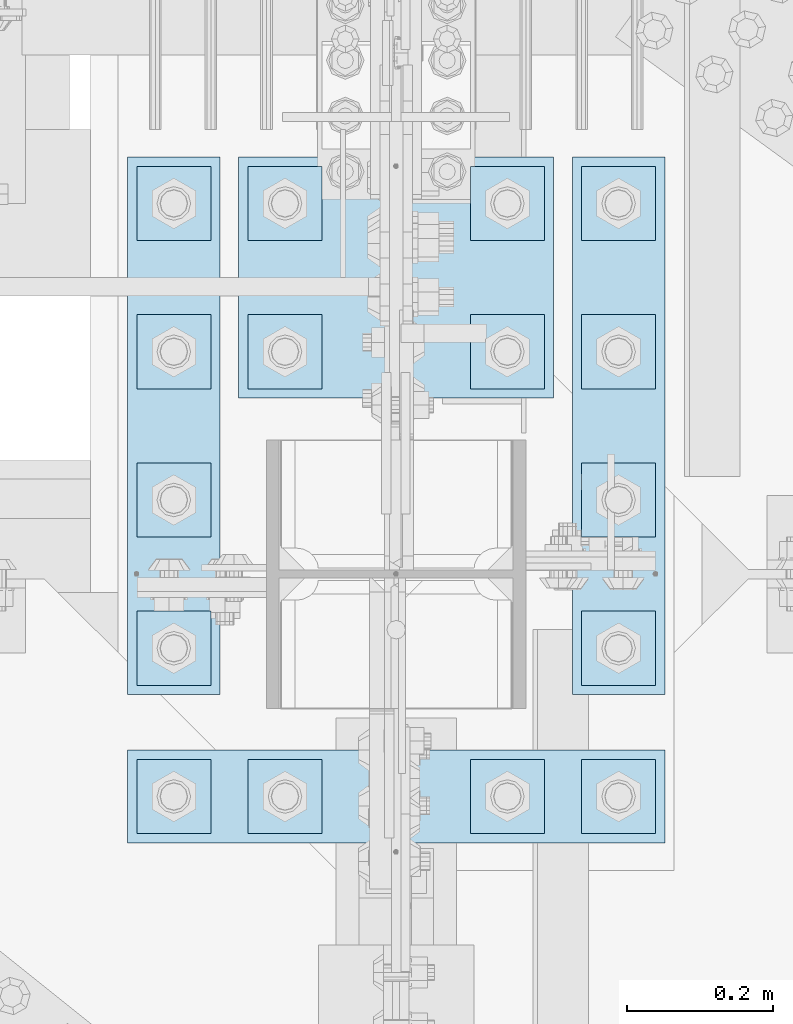
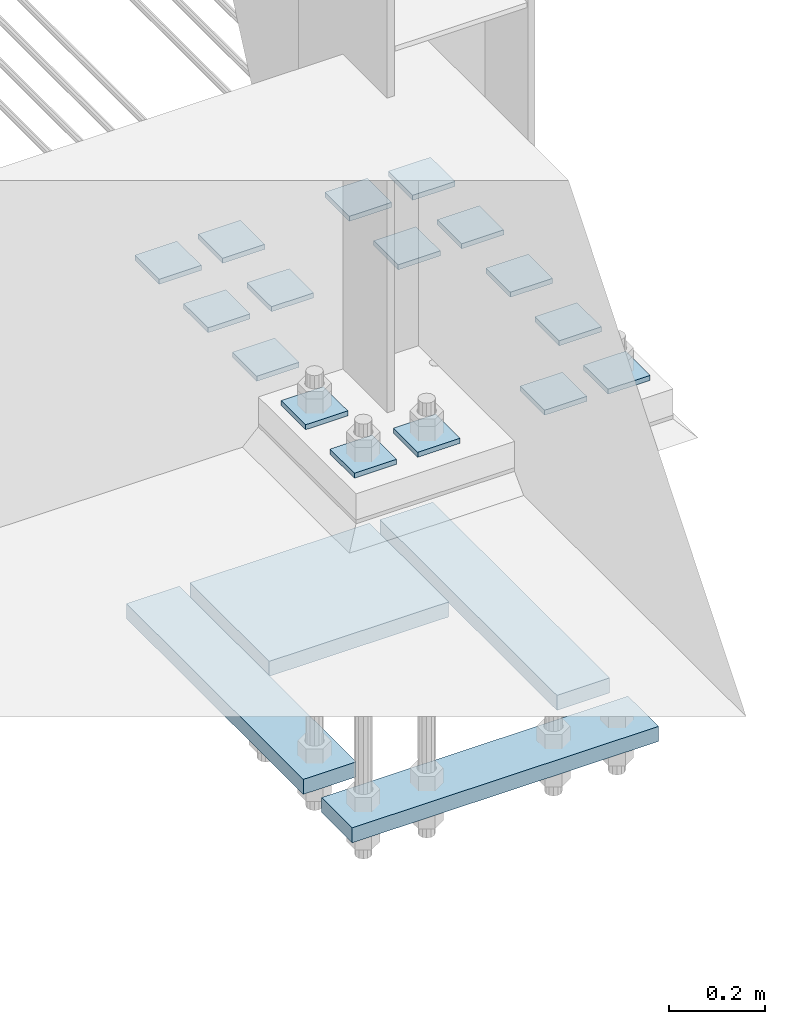
# One storey, part 3515 of 3843: 20 plates, 1 element without a shape of its own.
"""IFC2X3 building model written with IfcOpenShell, lengths in millimetres."""

from ifc_helpers import new_model, si_unit, frame, origin_with_axes, place, context, subcontext, project, spatial, faceted_brep, material, type_object, element, aggregate, save


model = new_model("IFC2X3")

# Units and contexts
model_context = context("Model", 3, precision=1e-05, world=origin_with_axes())
body_context = subcontext(model_context, "Body", "Model", "MODEL_VIEW")
ifc_project = project(units=[si_unit("LENGTHUNIT", "METRE", prefix="MILLI"), si_unit("AREAUNIT", "SQUARE_METRE"), si_unit("VOLUMEUNIT", "CUBIC_METRE"), si_unit("MASSUNIT", "GRAM", prefix="KILO"), si_unit("TIMEUNIT", "SECOND"), si_unit("PLANEANGLEUNIT", "RADIAN"), si_unit("SOLIDANGLEUNIT", "STERADIAN"), si_unit("THERMODYNAMICTEMPERATUREUNIT", "DEGREE_CELSIUS"), si_unit("LUMINOUSINTENSITYUNIT", "LUMEN")], contexts=[model_context])

# Site, building, storey
site_placement = place(None, origin_with_axes())
site = spatial("IfcSite", under=ifc_project, at=site_placement, CompositionType="ELEMENT")
building_placement = place(site_placement, origin_with_axes())
building = spatial("IfcBuilding", under=site, at=building_placement, Name="Undefined", CompositionType="ELEMENT")
storey_placement = place(building_placement, origin_with_axes())
storey = spatial("IfcBuildingStorey", under=building, at=storey_placement, Name="Undefined", CompositionType="ELEMENT", Elevation=0.0)

# Assembly, plates
assembly_placement = place(storey_placement, origin_with_axes())
assembly = element("IfcElementAssembly", 1, at=assembly_placement, inside=storey, Name="TEMPLATE", AssemblyPlace="NOTDEFINED", PredefinedType="RIGID_FRAME")
ifc_material = material(Name="STEEL/A572-50")
plate_type_1 = type_object("IfcPlateType", PredefinedType="NOTDEFINED")
plate_1_placement = place(assembly_placement, frame((77266.8, 91960.7, 29686.25), z_axis=(0.0, -1.0, 0.0), x_axis=(1.0, 0.0, 0.0)))
plate_1 = element("IfcPlate", 2, at=plate_1_placement, type_object=plate_type_1, material=ifc_material, Name="Washer Plate", context=body_context, shape_type="Brep", body=[
    faceted_brep([(0.0, -6.3499999046162, 0.0), (-1.67347025126219e-10, -6.35000000000582, 101.600000000151), (-1.67347025126219e-10, 6.35000000000582, 101.600000000151), (7.27595761418343e-12, 6.3499999046162, 0.0), (101.599998474121, -6.34999999999854, 101.599998474121), (101.599998474121, 6.34999999999854, 101.599998474121), (101.6, -6.34999999999854, 0.0), (101.6, 6.34999999999854, 0.0)], [[[0, 1, 2, 3]], [[1, 4, 5, 2]], [[4, 6, 7, 5]], [[6, 0, 3, 7]], [[5, 7, 3, 2]], [[6, 4, 1, 0]]]),
])
plate_2_placement = place(assembly_placement, frame((77266.8, 92163.9, 29686.25), z_axis=(0.0, -1.0, 0.0), x_axis=(1.0, 0.0, 0.0)))
plate_2 = element("IfcPlate", 3, at=plate_2_placement, type_object=plate_type_1, material=ifc_material, Name="Washer Plate", context=body_context, shape_type="Brep", body=[
    faceted_brep([(0.0, -6.3499999046162, 0.0), (-1.67347025126219e-10, -6.35000000000582, 101.600000000151), (-1.67347025126219e-10, 6.35000000000582, 101.600000000151), (7.27595761418343e-12, 6.3499999046162, 0.0), (101.599998474121, -6.34999999999854, 101.599998474121), (101.599998474121, 6.34999999999854, 101.599998474121), (101.6, -6.34999999999854, 0.0), (101.6, 6.34999999999854, 0.0)], [[[0, 1, 2, 3]], [[1, 4, 5, 2]], [[4, 6, 7, 5]], [[6, 0, 3, 7]], [[5, 7, 3, 2]], [[6, 4, 1, 0]]]),
])
plate_3_placement = place(assembly_placement, frame((77266.8, 92367.1, 29686.25), z_axis=(0.0, -1.0, 0.0), x_axis=(1.0, 0.0, 0.0)))
plate_3 = element("IfcPlate", 4, at=plate_3_placement, type_object=plate_type_1, material=ifc_material, Name="Washer Plate", context=body_context, shape_type="Brep", body=[
    faceted_brep([(0.0, -6.3499999046162, 0.0), (-1.67347025126219e-10, -6.35000000000582, 101.600000000151), (-1.67347025126219e-10, 6.35000000000582, 101.600000000151), (7.27595761418343e-12, 6.3499999046162, 0.0), (101.599998474121, -6.34999999999854, 101.599998474121), (101.599998474121, 6.34999999999854, 101.599998474121), (101.6, -6.34999999999854, 0.0), (101.6, 6.34999999999854, 0.0)], [[[0, 1, 2, 3]], [[1, 4, 5, 2]], [[4, 6, 7, 5]], [[6, 0, 3, 7]], [[5, 7, 3, 2]], [[6, 4, 1, 0]]]),
])
plate_4_placement = place(assembly_placement, frame((77266.8, 92570.3, 29686.25), z_axis=(0.0, -1.0, 0.0), x_axis=(1.0, 0.0, 0.0)))
plate_4 = element("IfcPlate", 5, at=plate_4_placement, type_object=plate_type_1, material=ifc_material, Name="Washer Plate", context=body_context, shape_type="Brep", body=[
    faceted_brep([(0.0, -6.3499999046162, 0.0), (-1.67347025126219e-10, -6.35000000000582, 101.600000000151), (-1.67347025126219e-10, 6.35000000000582, 101.600000000151), (7.27595761418343e-12, 6.3499999046162, 0.0), (101.599998474121, -6.34999999999854, 101.599998474121), (101.599998474121, 6.34999999999854, 101.599998474121), (101.6, -6.34999999999854, 0.0), (101.6, 6.34999999999854, 0.0)], [[[0, 1, 2, 3]], [[1, 4, 5, 2]], [[4, 6, 7, 5]], [[6, 0, 3, 7]], [[5, 7, 3, 2]], [[6, 4, 1, 0]]]),
])
plate_5_placement = place(assembly_placement, frame((77266.8, 92773.5, 29686.25), z_axis=(0.0, -1.0, 0.0), x_axis=(1.0, 0.0, 0.0)))
plate_5 = element("IfcPlate", 6, at=plate_5_placement, type_object=plate_type_1, material=ifc_material, Name="Washer Plate", context=body_context, shape_type="Brep", body=[
    faceted_brep([(0.0, -6.3499999046162, 0.0), (-1.67347025126219e-10, -6.35000000000582, 101.600000000151), (-1.67347025126219e-10, 6.35000000000582, 101.600000000151), (7.27595761418343e-12, 6.3499999046162, 0.0), (101.599998474121, -6.34999999999854, 101.599998474121), (101.599998474121, 6.34999999999854, 101.599998474121), (101.6, -6.34999999999854, 0.0), (101.6, 6.34999999999854, 0.0)], [[[0, 1, 2, 3]], [[1, 4, 5, 2]], [[4, 6, 7, 5]], [[6, 0, 3, 7]], [[5, 7, 3, 2]], [[6, 4, 1, 0]]]),
])
plate_6_placement = place(assembly_placement, frame((77114.4, 91960.7, 29686.25), z_axis=(0.0, -1.0, 0.0), x_axis=(1.0, 0.0, 0.0)))
plate_6 = element("IfcPlate", 7, at=plate_6_placement, type_object=plate_type_1, material=ifc_material, Name="Washer Plate", context=body_context, shape_type="Brep", body=[
    faceted_brep([(0.0, -6.3499999046162, 0.0), (-1.67347025126219e-10, -6.35000000000582, 101.600000000151), (-1.67347025126219e-10, 6.35000000000582, 101.600000000151), (7.27595761418343e-12, 6.3499999046162, 0.0), (101.599998474121, -6.34999999999854, 101.599998474121), (101.599998474121, 6.34999999999854, 101.599998474121), (101.6, -6.34999999999854, 0.0), (101.6, 6.34999999999854, 0.0)], [[[0, 1, 2, 3]], [[1, 4, 5, 2]], [[4, 6, 7, 5]], [[6, 0, 3, 7]], [[5, 7, 3, 2]], [[6, 4, 1, 0]]]),
])
plate_7_placement = place(assembly_placement, frame((77114.4, 92570.3, 29686.25), z_axis=(0.0, -1.0, 0.0), x_axis=(1.0, 0.0, 0.0)))
plate_7 = element("IfcPlate", 8, at=plate_7_placement, type_object=plate_type_1, material=ifc_material, Name="Washer Plate", context=body_context, shape_type="Brep", body=[
    faceted_brep([(0.0, -6.3499999046162, 0.0), (-1.67347025126219e-10, -6.35000000000582, 101.600000000151), (-1.67347025126219e-10, 6.35000000000582, 101.600000000151), (7.27595761418343e-12, 6.3499999046162, 0.0), (101.599998474121, -6.34999999999854, 101.599998474121), (101.599998474121, 6.34999999999854, 101.599998474121), (101.6, -6.34999999999854, 0.0), (101.6, 6.34999999999854, 0.0)], [[[0, 1, 2, 3]], [[1, 4, 5, 2]], [[4, 6, 7, 5]], [[6, 0, 3, 7]], [[5, 7, 3, 2]], [[6, 4, 1, 0]]]),
])
plate_8_placement = place(assembly_placement, frame((77114.4, 92773.5, 29686.25), z_axis=(0.0, -1.0, 0.0), x_axis=(1.0, 0.0, 0.0)))
plate_8 = element("IfcPlate", 9, at=plate_8_placement, type_object=plate_type_1, material=ifc_material, Name="Washer Plate", context=body_context, shape_type="Brep", body=[
    faceted_brep([(0.0, -6.3499999046162, 0.0), (-1.67347025126219e-10, -6.35000000000582, 101.600000000151), (-1.67347025126219e-10, 6.35000000000582, 101.600000000151), (7.27595761418343e-12, 6.3499999046162, 0.0), (101.599998474121, -6.34999999999854, 101.599998474121), (101.599998474121, 6.34999999999854, 101.599998474121), (101.6, -6.34999999999854, 0.0), (101.6, 6.34999999999854, 0.0)], [[[0, 1, 2, 3]], [[1, 4, 5, 2]], [[4, 6, 7, 5]], [[6, 0, 3, 7]], [[5, 7, 3, 2]], [[6, 4, 1, 0]]]),
])
plate_9_placement = place(assembly_placement, frame((76809.6, 91960.7, 29686.25), z_axis=(0.0, -1.0, 0.0), x_axis=(1.0, 0.0, 0.0)))
plate_9 = element("IfcPlate", 10, at=plate_9_placement, type_object=plate_type_1, material=ifc_material, Name="Washer Plate", context=body_context, shape_type="Brep", body=[
    faceted_brep([(0.0, -6.3499999046162, 0.0), (-1.67347025126219e-10, -6.35000000000582, 101.600000000151), (-1.67347025126219e-10, 6.35000000000582, 101.600000000151), (7.27595761418343e-12, 6.3499999046162, 0.0), (101.599998474121, -6.34999999999854, 101.599998474121), (101.599998474121, 6.34999999999854, 101.599998474121), (101.6, -6.34999999999854, 0.0), (101.6, 6.34999999999854, 0.0)], [[[0, 1, 2, 3]], [[1, 4, 5, 2]], [[4, 6, 7, 5]], [[6, 0, 3, 7]], [[5, 7, 3, 2]], [[6, 4, 1, 0]]]),
])
plate_10_placement = place(assembly_placement, frame((76809.6, 92570.3, 29686.25), z_axis=(0.0, -1.0, 0.0), x_axis=(1.0, 0.0, 0.0)))
plate_10 = element("IfcPlate", 11, at=plate_10_placement, type_object=plate_type_1, material=ifc_material, Name="Washer Plate", context=body_context, shape_type="Brep", body=[
    faceted_brep([(0.0, -6.3499999046162, 0.0), (-1.67347025126219e-10, -6.35000000000582, 101.600000000151), (-1.67347025126219e-10, 6.35000000000582, 101.600000000151), (7.27595761418343e-12, 6.3499999046162, 0.0), (101.599998474121, -6.34999999999854, 101.599998474121), (101.599998474121, 6.34999999999854, 101.599998474121), (101.6, -6.34999999999854, 0.0), (101.6, 6.34999999999854, 0.0)], [[[0, 1, 2, 3]], [[1, 4, 5, 2]], [[4, 6, 7, 5]], [[6, 0, 3, 7]], [[5, 7, 3, 2]], [[6, 4, 1, 0]]]),
])
plate_11_placement = place(assembly_placement, frame((76809.6, 92773.5, 29686.25), z_axis=(0.0, -1.0, 0.0), x_axis=(1.0, 0.0, 0.0)))
plate_11 = element("IfcPlate", 12, at=plate_11_placement, type_object=plate_type_1, material=ifc_material, Name="Washer Plate", context=body_context, shape_type="Brep", body=[
    faceted_brep([(0.0, -6.3499999046162, 0.0), (-1.67347025126219e-10, -6.35000000000582, 101.600000000151), (-1.67347025126219e-10, 6.35000000000582, 101.600000000151), (7.27595761418343e-12, 6.3499999046162, 0.0), (101.599998474121, -6.34999999999854, 101.599998474121), (101.599998474121, 6.34999999999854, 101.599998474121), (101.6, -6.34999999999854, 0.0), (101.6, 6.34999999999854, 0.0)], [[[0, 1, 2, 3]], [[1, 4, 5, 2]], [[4, 6, 7, 5]], [[6, 0, 3, 7]], [[5, 7, 3, 2]], [[6, 4, 1, 0]]]),
])
plate_12_placement = place(assembly_placement, frame((76657.2, 91960.7, 29686.25), z_axis=(0.0, -1.0, 0.0), x_axis=(1.0, 0.0, 0.0)))
plate_12 = element("IfcPlate", 13, at=plate_12_placement, type_object=plate_type_1, material=ifc_material, Name="Washer Plate", context=body_context, shape_type="Brep", body=[
    faceted_brep([(0.0, -6.3499999046162, 0.0), (-1.67347025126219e-10, -6.35000000000582, 101.600000000151), (-1.67347025126219e-10, 6.35000000000582, 101.600000000151), (7.27595761418343e-12, 6.3499999046162, 0.0), (101.599998474121, -6.34999999999854, 101.599998474121), (101.599998474121, 6.34999999999854, 101.599998474121), (101.6, -6.34999999999854, 0.0), (101.6, 6.34999999999854, 0.0)], [[[0, 1, 2, 3]], [[1, 4, 5, 2]], [[4, 6, 7, 5]], [[6, 0, 3, 7]], [[5, 7, 3, 2]], [[6, 4, 1, 0]]]),
])
plate_13_placement = place(assembly_placement, frame((76657.2, 92163.9, 29686.25), z_axis=(0.0, -1.0, 0.0), x_axis=(1.0, 0.0, 0.0)))
plate_13 = element("IfcPlate", 14, at=plate_13_placement, type_object=plate_type_1, material=ifc_material, Name="Washer Plate", context=body_context, shape_type="Brep", body=[
    faceted_brep([(0.0, -6.3499999046162, 0.0), (-1.67347025126219e-10, -6.35000000000582, 101.600000000151), (-1.67347025126219e-10, 6.35000000000582, 101.600000000151), (7.27595761418343e-12, 6.3499999046162, 0.0), (101.599998474121, -6.34999999999854, 101.599998474121), (101.599998474121, 6.34999999999854, 101.599998474121), (101.6, -6.34999999999854, 0.0), (101.6, 6.34999999999854, 0.0)], [[[0, 1, 2, 3]], [[1, 4, 5, 2]], [[4, 6, 7, 5]], [[6, 0, 3, 7]], [[5, 7, 3, 2]], [[6, 4, 1, 0]]]),
])
plate_14_placement = place(assembly_placement, frame((76657.2, 92367.1, 29686.25), z_axis=(0.0, -1.0, 0.0), x_axis=(1.0, 0.0, 0.0)))
plate_14 = element("IfcPlate", 15, at=plate_14_placement, type_object=plate_type_1, material=ifc_material, Name="Washer Plate", context=body_context, shape_type="Brep", body=[
    faceted_brep([(0.0, -6.3499999046162, 0.0), (-1.67347025126219e-10, -6.35000000000582, 101.600000000151), (-1.67347025126219e-10, 6.35000000000582, 101.600000000151), (7.27595761418343e-12, 6.3499999046162, 0.0), (101.599998474121, -6.34999999999854, 101.599998474121), (101.599998474121, 6.34999999999854, 101.599998474121), (101.6, -6.34999999999854, 0.0), (101.6, 6.34999999999854, 0.0)], [[[0, 1, 2, 3]], [[1, 4, 5, 2]], [[4, 6, 7, 5]], [[6, 0, 3, 7]], [[5, 7, 3, 2]], [[6, 4, 1, 0]]]),
])
plate_15_placement = place(assembly_placement, frame((76657.2, 92570.3, 29686.25), z_axis=(0.0, -1.0, 0.0), x_axis=(1.0, 0.0, 0.0)))
plate_15 = element("IfcPlate", 16, at=plate_15_placement, type_object=plate_type_1, material=ifc_material, Name="Washer Plate", context=body_context, shape_type="Brep", body=[
    faceted_brep([(0.0, -6.3499999046162, 0.0), (-1.67347025126219e-10, -6.35000000000582, 101.600000000151), (-1.67347025126219e-10, 6.35000000000582, 101.600000000151), (7.27595761418343e-12, 6.3499999046162, 0.0), (101.599998474121, -6.34999999999854, 101.599998474121), (101.599998474121, 6.34999999999854, 101.599998474121), (101.6, -6.34999999999854, 0.0), (101.6, 6.34999999999854, 0.0)], [[[0, 1, 2, 3]], [[1, 4, 5, 2]], [[4, 6, 7, 5]], [[6, 0, 3, 7]], [[5, 7, 3, 2]], [[6, 4, 1, 0]]]),
])
plate_16_placement = place(assembly_placement, frame((76657.2, 92773.5, 29686.25), z_axis=(0.0, -1.0, 0.0), x_axis=(1.0, 0.0, 0.0)))
plate_16 = element("IfcPlate", 17, at=plate_16_placement, type_object=plate_type_1, material=ifc_material, Name="Washer Plate", context=body_context, shape_type="Brep", body=[
    faceted_brep([(0.0, -6.3499999046162, 0.0), (-1.67347025126219e-10, -6.35000000000582, 101.600000000151), (-1.67347025126219e-10, 6.35000000000582, 101.600000000151), (7.27595761418343e-12, 6.3499999046162, 0.0), (101.599998474121, -6.34999999999854, 101.599998474121), (101.599998474121, 6.34999999999854, 101.599998474121), (101.6, -6.34999999999854, 0.0), (101.6, 6.34999999999854, 0.0)], [[[0, 1, 2, 3]], [[1, 4, 5, 2]], [[4, 6, 7, 5]], [[6, 0, 3, 7]], [[5, 7, 3, 2]], [[6, 4, 1, 0]]]),
])
plate_type_2 = type_object("IfcPlateType", PredefinedType="NOTDEFINED")
plate_17_placement = place(assembly_placement, frame((76644.5, 91973.4, 28784.55), z_axis=(0.0, -1.0, 0.0), x_axis=(1.0, 0.0, 0.0)))
plate_17 = element("IfcPlate", 18, at=plate_17_placement, type_object=plate_type_2, material=ifc_material, Name="PLATE", context=body_context, shape_type="Brep", body=[
    faceted_brep([(0.0, -19.0500000000029, 0.0), (0.0, -19.0499999999993, 127.0), (0.0, 19.0499999999993, 127.0), (0.0, 19.0500000000029, 0.0), (736.599975585938, -19.0499999999993, 127.0), (736.599975585938, 19.0499999999993, 127.0), (736.599975585938, -19.0499999999993, 0.0), (736.599975585938, 19.0499999999993, 0.0)], [[[0, 1, 2, 3]], [[1, 4, 5, 2]], [[4, 6, 7, 5]], [[6, 0, 3, 7]], [[5, 7, 3, 2]], [[6, 4, 1, 0]]]),
])
plate_18_placement = place(assembly_placement, frame((76644.5, 92786.2, 28784.55), z_axis=(0.0, -1.0, 0.0), x_axis=(1.0, 0.0, 0.0)))
plate_18 = element("IfcPlate", 19, at=plate_18_placement, type_object=plate_type_2, material=ifc_material, Name="PLATE", context=body_context, shape_type="Brep", body=[
    faceted_brep([(0.0, -19.0500000000029, 0.0), (0.0, -19.0499999999993, 736.600036621094), (0.0, 19.0499999999993, 736.600036621094), (0.0, 19.0500000000029, 0.0), (127.0, -19.0499999999993, 736.600036621094), (127.0, 19.0499999999993, 736.600036621094), (127.0, -19.0499999999993, 0.0), (127.0, 19.0499999999993, 0.0)], [[[0, 1, 2, 3]], [[1, 4, 5, 2]], [[4, 6, 7, 5]], [[6, 0, 3, 7]], [[5, 7, 3, 2]], [[6, 4, 1, 0]]]),
])
plate_19_placement = place(assembly_placement, frame((77254.1, 92786.2, 28784.55), z_axis=(0.0, -1.0, 0.0), x_axis=(1.0, 0.0, 0.0)))
plate_19 = element("IfcPlate", 20, at=plate_19_placement, type_object=plate_type_2, material=ifc_material, Name="PLATE", context=body_context, shape_type="Brep", body=[
    faceted_brep([(0.0, -19.0500000000029, 0.0), (0.0, -19.0499999999993, 736.600036621094), (0.0, 19.0499999999993, 736.600036621094), (0.0, 19.0500000000029, 0.0), (127.0, -19.0499999999993, 736.600036621094), (127.0, 19.0499999999993, 736.600036621094), (127.0, -19.0499999999993, 0.0), (127.0, 19.0499999999993, 0.0)], [[[0, 1, 2, 3]], [[1, 4, 5, 2]], [[4, 6, 7, 5]], [[6, 0, 3, 7]], [[5, 7, 3, 2]], [[6, 4, 1, 0]]]),
])
plate_type_3 = type_object("IfcPlateType", PredefinedType="NOTDEFINED")
plate_20_placement = place(assembly_placement, frame((76796.9, 92786.2, 28784.55), z_axis=(0.0, -1.0, 0.0), x_axis=(1.0, 0.0, 0.0)))
plate_20 = element("IfcPlate", 21, at=plate_20_placement, type_object=plate_type_3, material=ifc_material, Name="PLATE", context=body_context, shape_type="Brep", body=[
    faceted_brep([(0.0, -19.0500000000029, 0.0), (0.0, -19.0499999999993, 330.200012207031), (0.0, 19.0499999999993, 330.200012207031), (0.0, 19.0500000000029, 0.0), (431.799957275391, -19.0499999999993, 330.200012207031), (431.799957275391, 19.0499999999993, 330.200012207031), (431.799957275391, -19.0499999999993, 0.0), (431.799957275391, 19.0499999999993, 0.0)], [[[0, 1, 2, 3]], [[1, 4, 5, 2]], [[4, 6, 7, 5]], [[6, 0, 3, 7]], [[5, 7, 3, 2]], [[6, 4, 1, 0]]]),
])
aggregate(assembly, [plate_17, plate_18, plate_19, plate_20, plate_1, plate_2, plate_3, plate_4, plate_5, plate_6, plate_7, plate_8, plate_9, plate_10, plate_11, plate_12, plate_13, plate_14, plate_15, plate_16])

save(model, "model.ifc")
